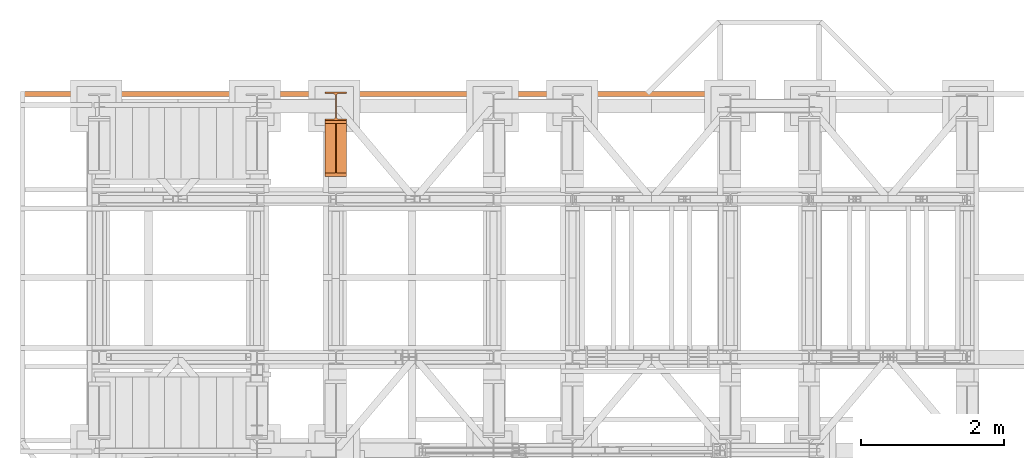
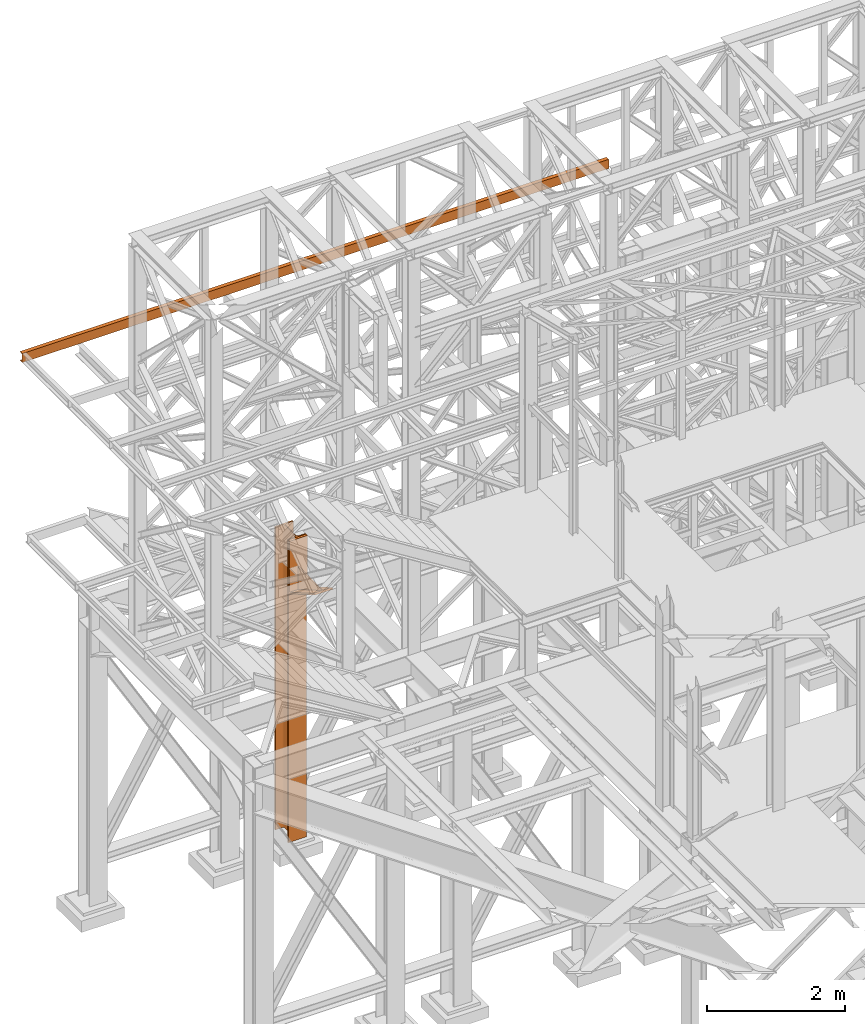
# One storey, part 138 of 208: 3 proxies.
"""IFC2X3 building model written with IfcOpenShell, lengths in millimetres."""

from ifc_helpers import new_model, entity, si_unit, converted_unit, frame, origin, origin_with_axes, place, context, subcontext, project, spatial, faceted_brep, element, save


model = new_model("IFC2X3")

# Units and contexts
model_context = context("Model", 3, precision=1e-05, world=origin())
plan_context = context("Plan", 3, precision=1e-05, world=origin())
body_context = subcontext(model_context, "Body", "Model", "MODEL_VIEW")
ifc_project = project(units=[si_unit("LENGTHUNIT", "METRE", prefix="MILLI"), converted_unit("PLANEANGLEUNIT", "DEGREE", entity("IfcPlaneAngleMeasure", 0.0174532925199433), si_unit("PLANEANGLEUNIT", "RADIAN"), dimensions=[0, 0, 0, 0, 0, 0, 0]), si_unit("AREAUNIT", "SQUARE_METRE"), si_unit("VOLUMEUNIT", "CUBIC_METRE")], contexts=[model_context, plan_context])

# Building, storey
building_placement = place(None, origin())
building = spatial("IfcBuilding", under=ifc_project, at=building_placement, CompositionType="COMPLEX")
storey_placement = place(building_placement, origin_with_axes())
storey = spatial("IfcBuildingStorey", under=building, at=storey_placement, Name="Geschoss", CompositionType="ELEMENT")

# Proxies
proxy_1_placement = place(storey_placement, frame((-156.7450314713294, -12666.57439173938, -65.01000000000022), z_axis=(0.0, 0.0, 1.0), x_axis=(1.0, 0.0, 0.0)))
element("IfcBuildingElementProxy", 1, at=proxy_1_placement, inside=storey, Name="3D Element", context=body_context, shape_type="Brep", body=[
    faceted_brep([(0.009999999999990905, 400.0100000000002, 5350.010005364416), (300.01, 400.0100000000002, 5350.010005364416), (300.01, 376.0100000000002, 5350.010005364416), (183.76, 376.0100000000002, 5350.010005364416), (175.4165694541391, 374.6884339422595, 5350.010005364416), (167.8898249341985, 370.8534254634014, 5350.010005364416), (161.9165745365979, 364.8801750658004, 5350.010005364416), (157.9269689743871, 356.3774142355142, 5350.010005364416), (156.76, 349.0100000000002, 5350.010005364416), (156.76, 51.01000000000022, 5350.010005364416), (158.0815660577403, 42.66656945413888, 5350.010005364416), (161.9165745365979, 35.13982493419826, 5350.010005364416), (167.8898249341985, 29.16657453659718, 5350.010005364416), (175.4165694541391, 25.33156605774093, 5350.010005364416), (183.76, 24.01000000000022, 5350.010005364416), (300.01, 24.01000000000022, 5350.010005364416), (300.01, 0.01000000000021828, 5350.010005364416), (0.009999999999990905, 0.01000000000021828, 5350.010005364416), (0.009999999999990905, 24.01000000000022, 5350.010005364416), (116.26, 24.01000000000022, 5350.010005364416), (124.6034305458604, 25.33156605774093, 5350.010005364416), (132.1301750658015, 29.16657453659718, 5350.010005364416), (138.1034254634017, 35.13982493419826, 5350.010005364416), (141.9384339422597, 42.66656945413888, 5350.010005364416), (143.26, 51.01000000000022, 5350.010005364416), (143.26, 347.9786887785685, 5350.010005364416), (141.9384339422597, 357.3534305458597, 5350.010005364416), (138.1034254634021, 364.8801750658004, 5350.010005364416), (132.1301750658015, 370.8534254634014, 5350.010005364416), (124.6034305458604, 374.6884339422595, 5350.010005364416), (115.0308095164803, 376.0100000000002, 5350.010005364416), (0.009999999999990905, 376.0100000000002, 5350.010005364416), (300.01, 400.0100000000002, 5350.010005364416), (0.009999999999990905, 400.0100000000002, 5350.010005364416), (0.009999999999990905, 400.0100000000002, 0.01000000000021828), (300.01, 400.0100000000002, 0.01000000000021828), (300.01, 376.0100000000002, 5350.010005364416), (300.01, 400.0100000000002, 5350.010005364416), (300.01, 400.0100000000002, 0.01000000000021828), (300.01, 376.0100000000002, 0.01000000000021828), (183.76, 376.0100000000002, 5350.010005364416), (300.01, 376.0100000000002, 5350.010005364416), (300.01, 376.0100000000002, 0.01000000000021828), (183.76, 376.0100000000002, 0.01000000000021828), (175.4165694541391, 374.6884339422595, 5350.010005364416), (183.76, 376.0100000000002, 5350.010005364416), (183.76, 376.0100000000002, 0.01000000000021828), (175.4165694541391, 374.6884339422595, 0.01000000000021828), (167.8898249341985, 370.8534254634014, 5350.010005364416), (175.4165694541391, 374.6884339422595, 5350.010005364416), (175.4165694541391, 374.6884339422595, 0.01000000000021828), (167.8898249341985, 370.8534254634014, 0.01000000000021828), (161.9165745365979, 364.8801750658004, 5350.010005364416), (167.8898249341985, 370.8534254634014, 5350.010005364416), (167.8898249341985, 370.8534254634014, 0.01000000000021828), (161.9165745365979, 364.8801750658004, 0.01000000000021828), (157.9269689743871, 356.3774142355142, 5350.010005364416), (161.9165745365979, 364.8801750658004, 5350.010005364416), (161.9165745365979, 364.8801750658004, 0.01000000000021828), (157.9269689743871, 356.3774142355142, 0.01000000000021828), (156.76, 349.0100000000002, 5350.010005364416), (157.9269689743871, 356.3774142355142, 5350.010005364416), (157.9269689743871, 356.3774142355142, 0.01000000000021828), (156.76, 349.0100000000002, 0.01000000000021828), (156.76, 51.01000000000022, 5350.010005364416), (156.76, 349.0100000000002, 5350.010005364416), (156.76, 349.0100000000002, 0.01000000000021828), (156.76, 51.01000000000022, 0.01000000000021828), (158.0815660577403, 42.66656945413888, 5350.010005364416), (156.76, 51.01000000000022, 5350.010005364416), (156.76, 51.01000000000022, 0.01000000000021828), (158.0815660577403, 42.66656945413888, 0.01000000000021828), (161.9165745365979, 35.13982493419826, 5350.010005364416), (158.0815660577403, 42.66656945413888, 5350.010005364416), (158.0815660577403, 42.66656945413888, 0.01000000000021828), (161.9165745365979, 35.13982493419826, 0.01000000000021828), (167.8898249341985, 29.16657453659718, 5350.010005364416), (161.9165745365979, 35.13982493419826, 5350.010005364416), (161.9165745365979, 35.13982493419826, 0.01000000000021828), (167.8898249341985, 29.16657453659718, 0.01000000000021828), (175.4165694541391, 25.33156605774093, 5350.010005364416), (167.8898249341985, 29.16657453659718, 5350.010005364416), (167.8898249341985, 29.16657453659718, 0.01000000000021828), (175.4165694541391, 25.33156605774093, 0.01000000000021828), (183.76, 24.01000000000022, 5350.010005364416), (175.4165694541391, 25.33156605774093, 5350.010005364416), (175.4165694541391, 25.33156605774093, 0.01000000000021828), (183.76, 24.01000000000022, 0.01000000000021828), (300.01, 24.01000000000022, 5350.010005364416), (183.76, 24.01000000000022, 5350.010005364416), (183.76, 24.01000000000022, 0.01000000000021828), (300.01, 24.01000000000022, 0.01000000000021828), (300.01, 0.01000000000021828, 5350.010005364416), (300.01, 24.01000000000022, 5350.010005364416), (300.01, 24.01000000000022, 0.01000000000021828), (300.01, 0.01000000000021828, 0.01000000000021828), (0.009999999999990905, 0.01000000000021828, 5350.010005364416), (300.01, 0.01000000000021828, 5350.010005364416), (300.01, 0.01000000000021828, 0.01000000000021828), (0.009999999999990905, 0.01000000000021828, 0.01000000000021828), (0.009999999999990905, 24.01000000000022, 5350.010005364416), (0.009999999999990905, 0.01000000000021828, 5350.010005364416), (0.009999999999990905, 0.01000000000021828, 0.01000000000021828), (0.009999999999990905, 24.01000000000022, 0.01000000000021828), (116.26, 24.01000000000022, 5350.010005364416), (0.009999999999990905, 24.01000000000022, 5350.010005364416), (0.009999999999990905, 24.01000000000022, 0.01000000000021828), (116.26, 24.01000000000022, 0.01000000000021828), (124.6034305458604, 25.33156605774093, 5350.010005364416), (116.26, 24.01000000000022, 5350.010005364416), (116.26, 24.01000000000022, 0.01000000000021828), (124.6034305458604, 25.33156605774093, 0.01000000000021828), (132.1301750658015, 29.16657453659718, 5350.010005364416), (124.6034305458604, 25.33156605774093, 5350.010005364416), (124.6034305458604, 25.33156605774093, 0.01000000000021828), (132.1301750658015, 29.16657453659718, 0.01000000000021828), (138.1034254634017, 35.13982493419826, 5350.010005364416), (132.1301750658015, 29.16657453659718, 5350.010005364416), (132.1301750658015, 29.16657453659718, 0.01000000000021828), (138.1034254634017, 35.13982493419826, 0.01000000000021828), (141.9384339422597, 42.66656945413888, 5350.010005364416), (138.1034254634017, 35.13982493419826, 5350.010005364416), (138.1034254634017, 35.13982493419826, 0.01000000000021828), (141.9384339422597, 42.66656945413888, 0.01000000000021828), (143.26, 51.01000000000022, 5350.010005364416), (141.9384339422597, 42.66656945413888, 5350.010005364416), (141.9384339422597, 42.66656945413888, 0.01000000000021828), (143.26, 51.01000000000022, 0.01000000000021828), (143.26, 347.9786887785685, 5350.010005364416), (143.26, 51.01000000000022, 5350.010005364416), (143.26, 51.01000000000022, 0.01000000000021828), (143.26, 347.9786887785685, 0.01000000000021828), (141.9384339422597, 357.3534305458597, 5350.010005364416), (143.26, 347.9786887785685, 5350.010005364416), (143.26, 347.9786887785685, 0.01000000000021828), (141.9384339422597, 357.3534305458597, 0.01000000000021828), (138.1034254634021, 364.8801750658004, 5350.010005364416), (141.9384339422597, 357.3534305458597, 5350.010005364416), (141.9384339422597, 357.3534305458597, 0.01000000000021828), (138.1034254634021, 364.8801750658004, 0.01000000000021828), (132.1301750658015, 370.8534254634014, 5350.010005364416), (138.1034254634021, 364.8801750658004, 5350.010005364416), (138.1034254634021, 364.8801750658004, 0.01000000000021828), (132.1301750658015, 370.8534254634014, 0.01000000000021828), (124.6034305458604, 374.6884339422595, 5350.010005364416), (132.1301750658015, 370.8534254634014, 5350.010005364416), (132.1301750658015, 370.8534254634014, 0.01000000000021828), (124.6034305458604, 374.6884339422595, 0.01000000000021828), (115.0308095164803, 376.0100000000002, 5350.010005364416), (124.6034305458604, 374.6884339422595, 5350.010005364416), (124.6034305458604, 374.6884339422595, 0.01000000000021828), (115.0308095164803, 376.0100000000002, 0.01000000000021828), (0.009999999999990905, 376.0100000000002, 5350.010005364416), (115.0308095164803, 376.0100000000002, 5350.010005364416), (115.0308095164803, 376.0100000000002, 0.01000000000021828), (0.009999999999990905, 376.0100000000002, 0.01000000000021828), (0.009999999999990905, 400.0100000000002, 5350.010005364416), (0.009999999999990905, 376.0100000000002, 5350.010005364416), (0.009999999999990905, 376.0100000000002, 0.01000000000021828), (0.009999999999990905, 400.0100000000002, 0.01000000000021828), (0.009999999999990905, 400.0100000000002, 0.01000000000021828), (0.009999999999990905, 376.0100000000002, 0.01000000000021828), (115.0308095164803, 376.0100000000002, 0.01000000000021828), (124.6034305458604, 374.6884339422595, 0.01000000000021828), (132.1301750658015, 370.8534254634014, 0.01000000000021828), (138.1034254634021, 364.8801750658004, 0.01000000000021828), (141.9384339422597, 357.3534305458597, 0.01000000000021828), (143.26, 347.9786887785685, 0.01000000000021828), (143.26, 51.01000000000022, 0.01000000000021828), (141.9384339422597, 42.66656945413888, 0.01000000000021828), (138.1034254634017, 35.13982493419826, 0.01000000000021828), (132.1301750658015, 29.16657453659718, 0.01000000000021828), (124.6034305458604, 25.33156605774093, 0.01000000000021828), (116.26, 24.01000000000022, 0.01000000000021828), (0.009999999999990905, 24.01000000000022, 0.01000000000021828), (0.009999999999990905, 0.01000000000021828, 0.01000000000021828), (300.01, 0.01000000000021828, 0.01000000000021828), (300.01, 24.01000000000022, 0.01000000000021828), (183.76, 24.01000000000022, 0.01000000000021828), (175.4165694541391, 25.33156605774093, 0.01000000000021828), (167.8898249341985, 29.16657453659718, 0.01000000000021828), (161.9165745365979, 35.13982493419826, 0.01000000000021828), (158.0815660577403, 42.66656945413888, 0.01000000000021828), (156.76, 51.01000000000022, 0.01000000000021828), (156.76, 349.0100000000002, 0.01000000000021828), (157.9269689743871, 356.3774142355142, 0.01000000000021828), (161.9165745365979, 364.8801750658004, 0.01000000000021828), (167.8898249341985, 370.8534254634014, 0.01000000000021828), (175.4165694541391, 374.6884339422595, 0.01000000000021828), (183.76, 376.0100000000002, 0.01000000000021828), (300.01, 376.0100000000002, 0.01000000000021828), (300.01, 400.0100000000002, 0.01000000000021828)], [[[0, 1, 2, 3, 4, 5, 6, 7, 8, 9, 10, 11, 12, 13, 14, 15, 16, 17, 18, 19, 20, 21, 22, 23, 24, 25, 26, 27, 28, 29, 30, 31]], [[32, 33, 34, 35]], [[36, 37, 38, 39]], [[40, 41, 42, 43]], [[44, 45, 46, 47]], [[48, 49, 50, 51]], [[52, 53, 54, 55]], [[56, 57, 58, 59]], [[60, 61, 62, 63]], [[64, 65, 66, 67]], [[68, 69, 70, 71]], [[72, 73, 74, 75]], [[76, 77, 78, 79]], [[80, 81, 82, 83]], [[84, 85, 86, 87]], [[88, 89, 90, 91]], [[92, 93, 94, 95]], [[96, 97, 98, 99]], [[100, 101, 102, 103]], [[104, 105, 106, 107]], [[108, 109, 110, 111]], [[112, 113, 114, 115]], [[116, 117, 118, 119]], [[120, 121, 122, 123]], [[124, 125, 126, 127]], [[128, 129, 130, 131]], [[132, 133, 134, 135]], [[136, 137, 138, 139]], [[140, 141, 142, 143]], [[144, 145, 146, 147]], [[148, 149, 150, 151]], [[152, 153, 154, 155]], [[156, 157, 158, 159]], [[160, 161, 162, 163, 164, 165, 166, 167, 168, 169, 170, 171, 172, 173, 174, 175, 176, 177, 178, 179, 180, 181, 182, 183, 184, 185, 186, 187, 188, 189, 190, 191]]], orient=[[False], [False], [False], [False], [False], [False], [False], [False], [False], [False], [False], [False], [False], [False], [False], [False], [False], [False], [False], [False], [False], [False], [False], [False], [False], [False], [False], [False], [False], [False], [False], [False], [False], [False]]),
])
proxy_2_placement = place(storey_placement, frame((-156.7450314713294, -13446.43639173938, 4339.230005364416), z_axis=(0.0, 0.0, 1.0), x_axis=(1.0, 0.0, 0.0)))
element("IfcBuildingElementProxy", 2, at=proxy_2_placement, inside=storey, context=body_context, shape_type="Brep", body=[
    faceted_brep([(0.009999999999990905, 739.8720000000012, 18.61000000000058), (0.009999999999990905, 0.01000000000203727, 445.7700000000004), (300.01, 0.01000000000021828, 445.7700000000004), (300.01, 739.8720000000012, 18.61000000000058), (0.009999999999990905, 0.01000000000203727, 445.7700000000004), (0.009999999999990905, 50.06600000000071, 445.7710000000006), (142.51, 50.06600000000071, 445.7710000000006), (157.51, 50.06600000000071, 445.7710000000006), (300.01, 50.06600000000071, 445.7710000000006), (300.01, 0.01000000000021828, 445.7700000000004), (0.009999999999990905, 50.06600000000071, 445.7710000000006), (0.009999999999990905, 739.8720000000012, 47.51000000000022), (142.51, 739.8720000000012, 47.51000000000022), (142.51, 50.06600000000071, 445.7710000000006), (157.51, 739.8720000000012, 47.51000000000022), (300.01, 739.8720000000012, 47.51000000000022), (300.01, 50.06600000000071, 445.7710000000006), (157.51, 50.06600000000071, 445.7710000000006), (0.009999999999990905, 739.8720000000012, 18.61000000000058), (0.009999999999990905, 739.8720000000012, 0.01000000000021828), (0.009999999999990905, 779.8720000000012, 0.01000000000021828), (0.009999999999990905, 779.8719999999994, 945.7700000000004), (0.009999999999990905, 739.8720000000012, 945.7700000000004), (0.009999999999990905, 739.8720000000012, 47.51000000000022), (0.009999999999990905, 50.06600000000071, 445.7710000000006), (0.009999999999990905, 0.01000000000203727, 445.7700000000004), (300.01, 779.8719999999994, 945.7700000000004), (300.01, 779.8720000000012, 0.01000000000021828), (300.01, 739.8720000000012, 0.01000000000021828), (300.01, 739.8720000000012, 18.61000000000058), (300.01, 0.01000000000021828, 445.7700000000004), (300.01, 50.06600000000071, 445.7710000000006), (300.01, 739.8720000000012, 47.51000000000022), (300.01, 739.8719999999994, 945.7700000000004), (300.01, 779.8719999999994, 945.7700000000004), (300.01, 739.8719999999994, 945.7700000000004), (0.009999999999990905, 739.8720000000012, 945.7700000000004), (0.009999999999990905, 779.8719999999994, 945.7700000000004), (300.01, 739.8719999999994, 945.7700000000004), (300.01, 739.8720000000012, 47.51000000000022), (157.51, 739.8720000000012, 47.51000000000022), (157.51, 739.8720000000012, 445.7700000000004), (142.51, 739.8720000000012, 445.7700000000004), (142.51, 739.8720000000012, 47.51000000000022), (0.009999999999990905, 739.8720000000012, 47.51000000000022), (0.009999999999990905, 739.8720000000012, 945.7700000000004), (300.01, 739.8720000000012, 18.61000000000058), (300.01, 739.8720000000012, 0.01000000000021828), (0.009999999999990905, 739.8720000000012, 0.01000000000021828), (0.009999999999990905, 739.8720000000012, 18.61000000000058), (300.01, 739.8720000000012, 0.01000000000021828), (300.01, 779.8720000000012, 0.01000000000021828), (0.009999999999990905, 779.8720000000012, 0.01000000000021828), (0.009999999999990905, 739.8720000000012, 0.01000000000021828), (300.01, 779.8720000000012, 0.01000000000021828), (300.01, 779.8719999999994, 945.7700000000004), (0.009999999999990905, 779.8719999999994, 945.7700000000004), (0.009999999999990905, 779.8720000000012, 0.01000000000021828), (142.51, 50.06600000000071, 445.7710000000006), (142.51, 739.8720000000012, 445.7700000000004), (157.51, 739.8720000000012, 445.7700000000004), (157.51, 50.06600000000071, 445.7710000000006), (142.51, 739.8720000000012, 47.51000000000022), (142.51, 739.8720000000012, 445.7700000000004), (142.51, 50.06600000000071, 445.7710000000006), (157.51, 739.8720000000012, 47.51000000000022), (157.51, 50.06600000000071, 445.7710000000006), (157.51, 739.8720000000012, 445.7700000000004)], [[[0, 1, 2, 3]], [[4, 5, 6, 7, 8, 9]], [[10, 11, 12, 13]], [[14, 15, 16, 17]], [[18, 19, 20, 21, 22, 23, 24, 25]], [[26, 27, 28, 29, 30, 31, 32, 33]], [[34, 35, 36, 37]], [[38, 39, 40, 41, 42, 43, 44, 45]], [[46, 47, 48, 49]], [[50, 51, 52, 53]], [[54, 55, 56, 57]], [[58, 59, 60, 61]], [[62, 63, 64]], [[65, 66, 67]]], orient=[[False], [False], [False], [False], [False], [False], [False], [False], [False], [False], [False], [False], [False], [False]]),
])
proxy_3_placement = place(storey_placement, frame((-4406.745032961457, -12327.70550180781, 9699.99), z_axis=(0.0, 0.0, 1.0), x_axis=(1.0, 0.0, 0.0)))
element("IfcBuildingElementProxy", 3, at=proxy_3_placement, inside=storey, context=body_context, shape_type="Brep", body=[
    faceted_brep([(0.01000000000021828, 65.01000000000022, 0.01000000000021828), (9800.010000000007, 65.0099999999984, 0.01000000000021828), (9800.010000000007, 65.0099999999984, 3.132428070246533), (0.01000000000021828, 65.01000000000022, 3.132428070246533), (0.01000000000021828, 65.01000000000022, 3.132428070246533), (9800.010000000007, 65.0099999999984, 3.132428070246533), (9800.010000000007, 64.76726342282382, 4.748288908171162), (0.01000000000021828, 64.76726342282745, 4.748288908171162), (0.01000000000021828, 64.76726342282745, 4.748288908171162), (9800.010000000007, 64.76726342282382, 4.748288908171162), (9800.010000000007, 64.06053228585552, 6.221534443444398), (0.01000000000021828, 64.06053228585552, 6.221534443444398), (0.01000000000021828, 64.06053228585552, 6.221534443444398), (9800.010000000007, 64.06053228585552, 6.221534443444398), (9800.010000000007, 62.9521516384666, 7.422126703873801), (0.01000000000021828, 62.95215163846842, 7.422126703873801), (0.01000000000021828, 62.95215163846842, 7.422126703873801), (9800.010000000007, 62.9521516384666, 7.422126703873801), (9800.010000000007, 61.53995641148322, 8.244091391710754), (0.01000000000021828, 61.53995641148504, 8.244091391710754), (0.01000000000021828, 61.53995641148504, 8.244091391710754), (9800.010000000007, 61.53995641148322, 8.244091391710754), (9800.010000000007, 59.94859872255438, 8.614912102195376), (0.01000000000021828, 59.9485987225562, 8.614912102195376), (0.01000000000021828, 59.9485987225562, 8.614912102195376), (9800.010000000007, 59.94859872255438, 8.614912102195376), (9800.010000000007, 17.17267516602806, 12.0369859867169), (0.01000000000021828, 17.17267516602988, 12.0369859867169), (0.01000000000021828, 17.17267516602988, 12.0369859867169), (9800.010000000007, 17.17267516602806, 12.0369859867169), (9800.010000000007, 14.13462866898226, 12.74491643400506), (0.01000000000021828, 14.13462866898408, 12.74491643400506), (0.01000000000021828, 14.13462866898408, 12.74491643400506), (9800.010000000007, 14.13462866898226, 12.74491643400506), (9800.010000000007, 11.43861959928472, 14.31412174714933), (0.01000000000021828, 11.43861959928654, 14.31412174714933), (0.01000000000021828, 11.43861959928654, 14.31412174714933), (9800.010000000007, 11.43861959928472, 14.31412174714933), (9800.010000000007, 9.322620181545062, 16.60616151705835), (0.01000000000021828, 9.322620181546881, 16.60616151705835), (0.01000000000021828, 9.322620181546881, 16.60616151705835), (9800.010000000007, 9.322620181545062, 16.60616151705835), (9800.010000000007, 7.973406192782932, 19.41872117530875), (0.01000000000021828, 7.97340619278657, 19.41872117530875), (0.01000000000021828, 7.97340619278657, 19.41872117530875), (9800.010000000007, 7.973406192782932, 19.41872117530875), (9800.010000000007, 7.509999999998399, 22.50354641134618), (0.01000000000021828, 7.510000000000218, 22.50354641134618), (0.01000000000021828, 7.510000000000218, 22.50354641134618), (9800.010000000007, 7.509999999998399, 22.50354641134618), (9800.010000000007, 7.509999999998399, 137.5164535886524), (0.01000000000021828, 7.510000000000218, 137.5164535886524), (0.01000000000021828, 7.510000000000218, 137.5164535886524), (9800.010000000007, 7.509999999998399, 137.5164535886524), (9800.010000000007, 7.973406192782932, 140.6012788246917), (0.01000000000021828, 7.97340619278657, 140.6012788246917), (0.01000000000021828, 7.97340619278657, 140.6012788246917), (9800.010000000007, 7.973406192782932, 140.6012788246917), (9800.010000000007, 9.322620181545062, 143.4138384829403), (0.01000000000021828, 9.322620181546881, 143.4138384829403), (0.01000000000021828, 9.322620181546881, 143.4138384829403), (9800.010000000007, 9.322620181545062, 143.4138384829403), (9800.010000000007, 11.43861959928472, 145.7058782528493), (0.01000000000021828, 11.43861959928654, 145.7058782528493), (0.01000000000021828, 11.43861959928654, 145.7058782528493), (9800.010000000007, 11.43861959928472, 145.7058782528493), (9800.010000000007, 14.13462866898226, 147.2750835659936), (0.01000000000021828, 14.13462866898408, 147.2750835659936), (0.01000000000021828, 14.13462866898408, 147.2750835659936), (9800.010000000007, 14.13462866898226, 147.2750835659936), (9800.010000000007, 17.17267516602806, 147.9830140132817), (0.01000000000021828, 17.17267516602988, 147.9830140132817), (0.01000000000021828, 17.17267516602988, 147.9830140132817), (9800.010000000007, 17.17267516602806, 147.9830140132817), (9800.010000000007, 59.94859872255438, 151.4050878978032), (0.01000000000021828, 59.9485987225562, 151.4050878978032), (0.01000000000021828, 59.9485987225562, 151.4050878978032), (9800.010000000007, 59.94859872255438, 151.4050878978032), (9800.010000000007, 61.53995641148322, 151.7759086082879), (0.01000000000021828, 61.53995641148504, 151.7759086082879), (0.01000000000021828, 61.53995641148504, 151.7759086082879), (9800.010000000007, 61.53995641148322, 151.7759086082879), (9800.010000000007, 62.9521516384666, 152.5978732961248), (0.01000000000021828, 62.95215163846842, 152.5978732961248), (0.01000000000021828, 62.95215163846842, 152.5978732961248), (9800.010000000007, 62.9521516384666, 152.5978732961248), (9800.010000000007, 64.06053228585552, 153.7984655565542), (0.01000000000021828, 64.06053228585552, 153.7984655565542), (0.01000000000021828, 64.06053228585552, 153.7984655565542), (9800.010000000007, 64.06053228585552, 153.7984655565542), (9800.010000000007, 64.76726342282382, 155.2717110918275), (0.01000000000021828, 64.76726342282745, 155.2717110918275), (0.01000000000021828, 64.76726342282745, 155.2717110918275), (9800.010000000007, 64.76726342282382, 155.2717110918275), (9800.010000000007, 65.0099999999984, 156.8875719297521), (0.01000000000021828, 65.01000000000022, 156.8875719297521), (0.01000000000021828, 65.01000000000022, 156.8875719297521), (9800.010000000007, 65.0099999999984, 156.8875719297521), (9800.010000000007, 65.0099999999984, 160.0100000000002), (0.01000000000021828, 65.01000000000022, 160.0100000000002), (0.01000000000021828, 65.01000000000022, 160.0100000000002), (9800.010000000007, 65.0099999999984, 160.0100000000002), (9800.010000000007, 0.00999999999839929, 160.0100000000002), (0.01000000000021828, 0.01000000000021828, 160.0100000000002), (0.01000000000021828, 0.01000000000021828, 160.0100000000002), (9800.010000000007, 0.00999999999839929, 160.0100000000002), (9800.010000000007, 0.00999999999839929, 0.01000000000021828), (0.01000000000021828, 0.01000000000021828, 0.01000000000021828), (0.01000000000021828, 0.01000000000021828, 0.01000000000021828), (9800.010000000007, 0.00999999999839929, 0.01000000000021828), (9800.010000000007, 65.0099999999984, 0.01000000000021828), (0.01000000000021828, 65.01000000000022, 0.01000000000021828), (0.01000000000021828, 65.01000000000022, 0.01000000000021828), (0.01000000000021828, 65.01000000000022, 3.132428070246533), (0.01000000000021828, 64.76726342282745, 4.748288908171162), (0.01000000000021828, 64.06053228585552, 6.221534443444398), (0.01000000000021828, 62.95215163846842, 7.422126703873801), (0.01000000000021828, 61.53995641148504, 8.244091391710754), (0.01000000000021828, 59.9485987225562, 8.614912102195376), (0.01000000000021828, 17.17267516602988, 12.0369859867169), (0.01000000000021828, 14.13462866898408, 12.74491643400506), (0.01000000000021828, 11.43861959928654, 14.31412174714933), (0.01000000000021828, 9.322620181546881, 16.60616151705835), (0.01000000000021828, 7.97340619278657, 19.41872117530875), (0.01000000000021828, 7.510000000000218, 22.50354641134618), (0.01000000000021828, 7.510000000000218, 137.5164535886524), (0.01000000000021828, 7.97340619278657, 140.6012788246917), (0.01000000000021828, 9.322620181546881, 143.4138384829403), (0.01000000000021828, 11.43861959928654, 145.7058782528493), (0.01000000000021828, 14.13462866898408, 147.2750835659936), (0.01000000000021828, 17.17267516602988, 147.9830140132817), (0.01000000000021828, 59.9485987225562, 151.4050878978032), (0.01000000000021828, 61.53995641148504, 151.7759086082879), (0.01000000000021828, 62.95215163846842, 152.5978732961248), (0.01000000000021828, 64.06053228585552, 153.7984655565542), (0.01000000000021828, 64.76726342282745, 155.2717110918275), (0.01000000000021828, 65.01000000000022, 156.8875719297521), (0.01000000000021828, 65.01000000000022, 160.0100000000002), (0.01000000000021828, 0.01000000000021828, 160.0100000000002), (0.01000000000021828, 0.01000000000021828, 0.01000000000021828), (9800.010000000007, 65.0099999999984, 0.01000000000021828), (9800.010000000007, 0.00999999999839929, 0.01000000000021828), (9800.010000000007, 0.00999999999839929, 160.0100000000002), (9800.010000000007, 65.0099999999984, 160.0100000000002), (9800.010000000007, 65.0099999999984, 156.8875719297521), (9800.010000000007, 64.76726342282382, 155.2717110918275), (9800.010000000007, 64.06053228585552, 153.7984655565542), (9800.010000000007, 62.9521516384666, 152.5978732961248), (9800.010000000007, 61.53995641148322, 151.7759086082879), (9800.010000000007, 59.94859872255438, 151.4050878978032), (9800.010000000007, 17.17267516602806, 147.9830140132817), (9800.010000000007, 14.13462866898226, 147.2750835659936), (9800.010000000007, 11.43861959928472, 145.7058782528493), (9800.010000000007, 9.322620181545062, 143.4138384829403), (9800.010000000007, 7.973406192782932, 140.6012788246917), (9800.010000000007, 7.509999999998399, 137.5164535886524), (9800.010000000007, 7.509999999998399, 22.50354641134618), (9800.010000000007, 7.973406192782932, 19.41872117530875), (9800.010000000007, 9.322620181545062, 16.60616151705835), (9800.010000000007, 11.43861959928472, 14.31412174714933), (9800.010000000007, 14.13462866898226, 12.74491643400506), (9800.010000000007, 17.17267516602806, 12.0369859867169), (9800.010000000007, 59.94859872255438, 8.614912102195376), (9800.010000000007, 61.53995641148322, 8.244091391710754), (9800.010000000007, 62.9521516384666, 7.422126703873801), (9800.010000000007, 64.06053228585552, 6.221534443444398), (9800.010000000007, 64.76726342282382, 4.748288908171162), (9800.010000000007, 65.0099999999984, 3.132428070246533)], [[[0, 1, 2, 3]], [[4, 5, 6, 7]], [[8, 9, 10, 11]], [[12, 13, 14, 15]], [[16, 17, 18, 19]], [[20, 21, 22, 23]], [[24, 25, 26, 27]], [[28, 29, 30, 31]], [[32, 33, 34, 35]], [[36, 37, 38, 39]], [[40, 41, 42, 43]], [[44, 45, 46, 47]], [[48, 49, 50, 51]], [[52, 53, 54, 55]], [[56, 57, 58, 59]], [[60, 61, 62, 63]], [[64, 65, 66, 67]], [[68, 69, 70, 71]], [[72, 73, 74, 75]], [[76, 77, 78, 79]], [[80, 81, 82, 83]], [[84, 85, 86, 87]], [[88, 89, 90, 91]], [[92, 93, 94, 95]], [[96, 97, 98, 99]], [[100, 101, 102, 103]], [[104, 105, 106, 107]], [[108, 109, 110, 111]], [[112, 113, 114, 115, 116, 117, 118, 119, 120, 121, 122, 123, 124, 125, 126, 127, 128, 129, 130, 131, 132, 133, 134, 135, 136, 137, 138, 139]], [[140, 141, 142, 143, 144, 145, 146, 147, 148, 149, 150, 151, 152, 153, 154, 155, 156, 157, 158, 159, 160, 161, 162, 163, 164, 165, 166, 167]]], orient=[[False], [False], [False], [False], [False], [False], [False], [False], [False], [False], [False], [False], [False], [False], [False], [False], [False], [False], [False], [False], [False], [False], [False], [False], [False], [False], [False], [False], [False], [False]]),
])

save(model, "model.ifc")
